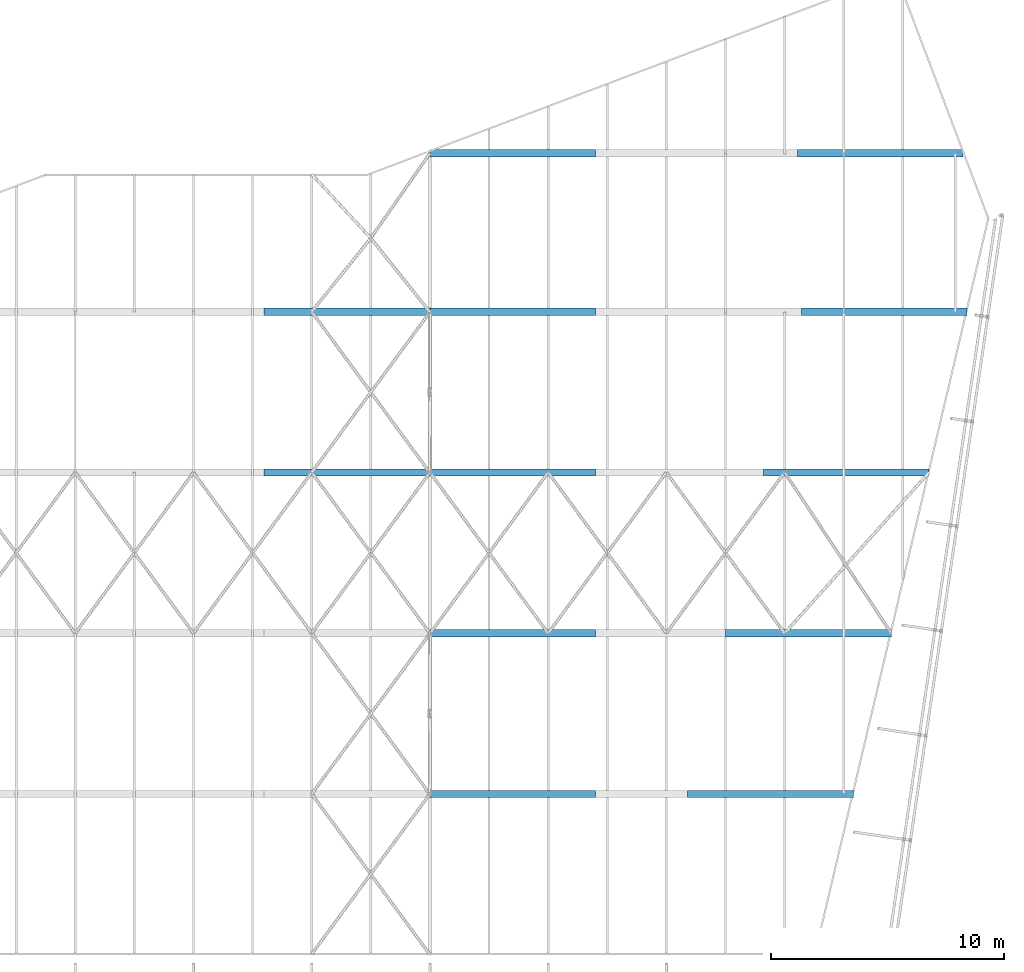
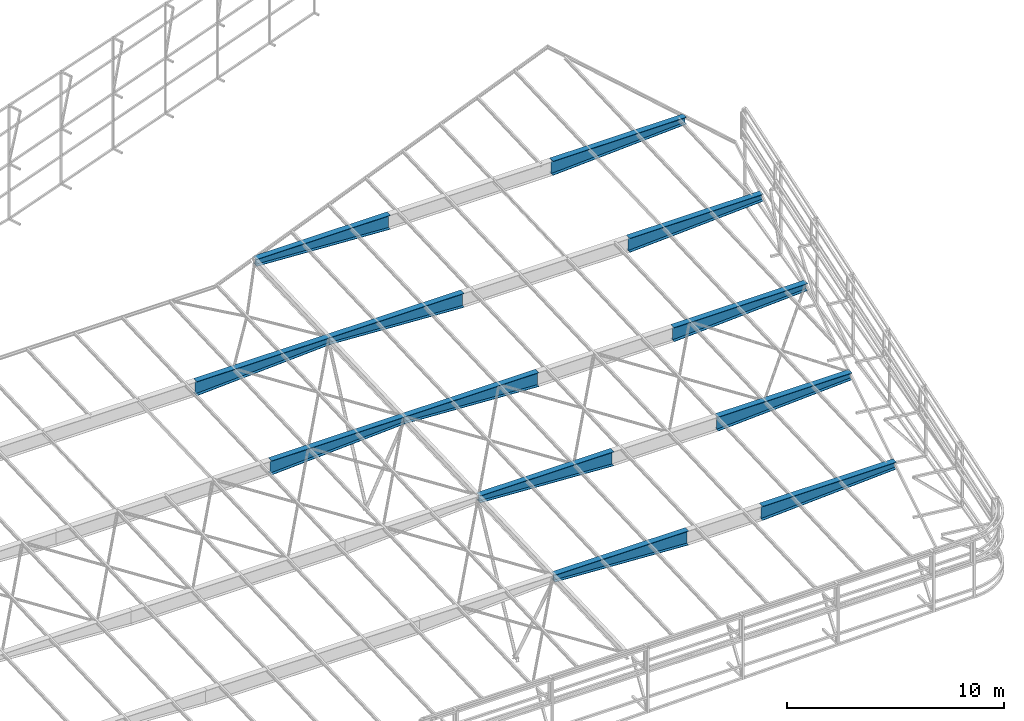
# One storey, part 215 of 215: 12 beams, 12 elements without a shape of their own.
"""IFC2X3 building model written with IfcOpenShell, lengths in millimetres."""

from ifc_helpers import new_model, si_unit, frame, origin_with_axes, place, context, subcontext, project, spatial, faceted_brep, material, type_object, element, aggregate, save


model = new_model("IFC2X3")

# Units and contexts
model_context = context("Model", 3, precision=1e-05, world=origin_with_axes())
body_context = subcontext(model_context, "Body", "Model", "MODEL_VIEW")
ifc_project = project(units=[si_unit("LENGTHUNIT", "METRE", prefix="MILLI"), si_unit("AREAUNIT", "SQUARE_METRE"), si_unit("VOLUMEUNIT", "CUBIC_METRE"), si_unit("MASSUNIT", "GRAM", prefix="KILO"), si_unit("TIMEUNIT", "SECOND"), si_unit("PLANEANGLEUNIT", "RADIAN"), si_unit("SOLIDANGLEUNIT", "STERADIAN"), si_unit("THERMODYNAMICTEMPERATUREUNIT", "DEGREE_CELSIUS"), si_unit("LUMINOUSINTENSITYUNIT", "LUMEN")], contexts=[model_context])

# Site, building, storey
site_placement = place(None, origin_with_axes())
site = spatial("IfcSite", under=ifc_project, at=site_placement, CompositionType="ELEMENT")
building_placement = place(site_placement, origin_with_axes())
building = spatial("IfcBuilding", under=site, at=building_placement, Name="Undefined", CompositionType="ELEMENT")
storey_placement = place(building_placement, origin_with_axes())
storey = spatial("IfcBuildingStorey", under=building, at=storey_placement, Name="Undefined", CompositionType="ELEMENT", Elevation=0.0)

# Assembly, beam
assembly_1_placement = place(storey_placement, origin_with_axes())
assembly_1 = element("IfcElementAssembly", 1, at=assembly_1_placement, inside=storey, Name="Steel Assembly", AssemblyPlace="NOTDEFINED", PredefinedType="RIGID_FRAME")
ifc_material = material(Name="STEEL/S355JR")
beam_type = type_object("IfcBeamType", PredefinedType="NOTDEFINED")
beam_1_placement = place(assembly_1_placement, frame((122402.809360299, 62582.036399848, 3827.69277739953), z_axis=(0.0, 0.0, -1.0), x_axis=(0.999999999241877, 3.89390000093188e-05, -9.99999996354785e-10)))
beam_1 = element("IfcBeam", 2, at=beam_1_placement, type_object=beam_type, material=ifc_material, Name="POUTRE", context=body_context, shape_type="Brep", body=[
    faceted_brep([(-2.91038304567337e-11, 160.000000000007, -200.0), (-2.91038304567337e-11, 160.000000000015, -180.0), (7122.15708385454, 160.000000000007, -180.0), (7122.15708385454, 160.000000000007, -200.0), (-2.91038304567337e-11, 3.00000000000728, -180.0), (7122.15708385453, 3.00000000000728, -180.0), (-1.45519152283669e-11, 3.00000000000728, 579.968482277901), (7122.15708385454, 3.00000000000728, 179.968482277901), (-2.91038304567337e-11, 160.000000000015, 579.968482277902), (7122.15708385454, 160.000000000007, 179.968482277902), (-4.36557456851006e-11, 160.000000000015, 600.0), (7122.15708385454, 160.000000000015, 200.0), (-2.91038304567337e-11, -159.999999999993, 600.0), (7122.15708385454, -160.0, 200.0), (-1.45519152283669e-11, -160.0, 579.968482277902), (7122.15708385454, -160.0, 179.968482277902), (-1.45519152283669e-11, -2.99999999998545, 579.968482277902), (7122.15708385453, -2.99999999998545, 179.968482277902), (-1.45519152283669e-11, -2.99999999998545, -180.0), (7122.15708385453, -2.99999999998545, -180.0), (-2.91038304567337e-11, -160.0, -180.0), (7122.15708385453, -160.0, -180.0), (-1.45519152283669e-11, -160.0, -200.0), (7122.15708385454, -160.0, -200.0)], [[[0, 1, 2, 3]], [[1, 4, 5, 2]], [[4, 6, 7, 5]], [[6, 8, 9, 7]], [[8, 10, 11, 9]], [[10, 12, 13, 11]], [[12, 14, 15, 13]], [[14, 16, 17, 15]], [[16, 18, 19, 17]], [[18, 20, 21, 19]], [[20, 22, 23, 21]], [[22, 0, 3, 23]], [[5, 7, 9, 11, 13, 15, 17, 19, 21, 23, 3, 2]], [[22, 20, 18, 16, 14, 12, 10, 8, 6, 4, 1, 0]]]),
])
aggregate(assembly_1, [beam_1])

assembly_2_placement = place(storey_placement, origin_with_axes())
assembly_2 = element("IfcElementAssembly", 3, at=assembly_2_placement, inside=storey, Name="Steel Assembly", AssemblyPlace="NOTDEFINED", PredefinedType="RIGID_FRAME")
beam_2_placement = place(assembly_2_placement, frame((122402.809360565, 55675.1952876719, 3551.4208334292), z_axis=(0.0, 0.0, -1.0), x_axis=(0.999999999241877, 3.89390000093188e-05, -9.99999996354785e-10)))
beam_2 = element("IfcBeam", 4, at=beam_2_placement, type_object=beam_type, material=ifc_material, Name="POUTRE", context=body_context, shape_type="Brep", body=[
    faceted_brep([(-2.91038304567337e-11, 160.000000000007, -200.0), (-2.91038304567337e-11, 160.000000000015, -180.0), (7122.15708385454, 160.000000000007, -180.0), (7122.15708385454, 160.000000000007, -200.0), (-2.91038304567337e-11, 3.00000000000728, -180.0), (7122.15708385453, 3.00000000000728, -180.0), (-1.45519152283669e-11, 3.00000000000728, 579.968482277901), (7122.15708385454, 3.00000000000728, 179.968482277901), (-2.91038304567337e-11, 160.000000000015, 579.968482277902), (7122.15708385454, 160.000000000007, 179.968482277902), (-4.36557456851006e-11, 160.000000000015, 600.0), (7122.15708385454, 160.000000000015, 200.0), (-2.91038304567337e-11, -159.999999999993, 600.0), (7122.15708385454, -160.0, 200.0), (-1.45519152283669e-11, -160.0, 579.968482277902), (7122.15708385454, -160.0, 179.968482277902), (-1.45519152283669e-11, -2.99999999998545, 579.968482277902), (7122.15708385453, -2.99999999998545, 179.968482277902), (-1.45519152283669e-11, -2.99999999998545, -180.0), (7122.15708385453, -2.99999999998545, -180.0), (-2.91038304567337e-11, -160.0, -180.0), (7122.15708385453, -160.0, -180.0), (-1.45519152283669e-11, -160.0, -200.0), (7122.15708385454, -160.0, -200.0)], [[[0, 1, 2, 3]], [[1, 4, 5, 2]], [[4, 6, 7, 5]], [[6, 8, 9, 7]], [[8, 10, 11, 9]], [[10, 12, 13, 11]], [[12, 14, 15, 13]], [[14, 16, 17, 15]], [[16, 18, 19, 17]], [[18, 20, 21, 19]], [[20, 22, 23, 21]], [[22, 0, 3, 23]], [[5, 7, 9, 11, 13, 15, 17, 19, 21, 23, 3, 2]], [[22, 20, 18, 16, 14, 12, 10, 8, 6, 4, 1, 0]]]),
])
aggregate(assembly_2, [beam_2])

assembly_3_placement = place(storey_placement, origin_with_axes())
assembly_3 = element("IfcElementAssembly", 5, at=assembly_3_placement, inside=storey, Name="Steel Assembly", AssemblyPlace="NOTDEFINED", PredefinedType="RIGID_FRAME")
beam_3_placement = place(assembly_3_placement, frame((136647.174047591, 69388.7234176693, 4099.95302041668), z_axis=(0.0, 0.0, -1.0), x_axis=(-0.999999999241877, 3.8939000009165e-05, -1.00000005517436e-09)))
beam_3 = element("IfcBeam", 6, at=beam_3_placement, type_object=beam_type, material=ifc_material, Name="POUTRE", context=body_context, shape_type="Brep", body=[
    faceted_brep([(-2.91038304567337e-11, 160.000000000007, -200.0), (-2.91038304567337e-11, 160.000000000015, -180.0), (7122.15708385454, 160.000000000007, -180.0), (7122.15708385454, 160.000000000007, -200.0), (-2.91038304567337e-11, 3.00000000000728, -180.0), (7122.15708385453, 3.00000000000728, -180.0), (-1.45519152283669e-11, 3.00000000000728, 579.968482277901), (7122.15708385454, 3.00000000000728, 179.968482277901), (-2.91038304567337e-11, 160.000000000015, 579.968482277902), (7122.15708385454, 160.000000000007, 179.968482277902), (-4.36557456851006e-11, 160.000000000015, 600.0), (7122.15708385454, 160.000000000015, 200.0), (-2.91038304567337e-11, -159.999999999993, 600.0), (7122.15708385454, -160.0, 200.0), (-1.45519152283669e-11, -160.0, 579.968482277902), (7122.15708385454, -160.0, 179.968482277902), (-1.45519152283669e-11, -2.99999999998545, 579.968482277902), (7122.15708385453, -2.99999999998545, 179.968482277902), (-1.45519152283669e-11, -2.99999999998545, -180.0), (7122.15708385453, -2.99999999998545, -180.0), (-2.91038304567337e-11, -160.0, -180.0), (7122.15708385453, -160.0, -180.0), (-1.45519152283669e-11, -160.0, -200.0), (7122.15708385454, -160.0, -200.0)], [[[0, 1, 2, 3]], [[1, 4, 5, 2]], [[4, 6, 7, 5]], [[6, 8, 9, 7]], [[8, 10, 11, 9]], [[10, 12, 13, 11]], [[12, 14, 15, 13]], [[14, 16, 17, 15]], [[16, 18, 19, 17]], [[18, 20, 21, 19]], [[20, 22, 23, 21]], [[22, 0, 3, 23]], [[5, 7, 9, 11, 13, 15, 17, 19, 21, 23, 3, 2]], [[22, 20, 18, 16, 14, 12, 10, 8, 6, 4, 1, 0]]]),
])
aggregate(assembly_3, [beam_3])

assembly_4_placement = place(storey_placement, origin_with_axes())
assembly_4 = element("IfcElementAssembly", 7, at=assembly_4_placement, inside=storey, Name="Steel Assembly", AssemblyPlace="NOTDEFINED", PredefinedType="RIGID_FRAME")
beam_4_placement = place(assembly_4_placement, frame((136647.210639701, 62582.036399848, 3827.69277739953), z_axis=(0.0, 0.0, -1.0), x_axis=(-0.999999999241877, 3.8939000009165e-05, -1.00000005517436e-09)))
beam_4 = element("IfcBeam", 8, at=beam_4_placement, type_object=beam_type, material=ifc_material, Name="POUTRE", context=body_context, shape_type="Brep", body=[
    faceted_brep([(-2.91038304567337e-11, 160.000000000007, -200.0), (-2.91038304567337e-11, 160.000000000015, -180.0), (7122.15708385454, 160.000000000007, -180.0), (7122.15708385454, 160.000000000007, -200.0), (-2.91038304567337e-11, 3.00000000000728, -180.0), (7122.15708385453, 3.00000000000728, -180.0), (-1.45519152283669e-11, 3.00000000000728, 579.968482277901), (7122.15708385454, 3.00000000000728, 179.968482277901), (-2.91038304567337e-11, 160.000000000015, 579.968482277902), (7122.15708385454, 160.000000000007, 179.968482277902), (-4.36557456851006e-11, 160.000000000015, 600.0), (7122.15708385454, 160.000000000015, 200.0), (-2.91038304567337e-11, -159.999999999993, 600.0), (7122.15708385454, -160.0, 200.0), (-1.45519152283669e-11, -160.0, 579.968482277902), (7122.15708385454, -160.0, 179.968482277902), (-1.45519152283669e-11, -2.99999999998545, 579.968482277902), (7122.15708385453, -2.99999999998545, 179.968482277902), (-1.45519152283669e-11, -2.99999999998545, -180.0), (7122.15708385453, -2.99999999998545, -180.0), (-2.91038304567337e-11, -160.0, -180.0), (7122.15708385453, -160.0, -180.0), (-1.45519152283669e-11, -160.0, -200.0), (7122.15708385454, -160.0, -200.0)], [[[0, 1, 2, 3]], [[1, 4, 5, 2]], [[4, 6, 7, 5]], [[6, 8, 9, 7]], [[8, 10, 11, 9]], [[10, 12, 13, 11]], [[12, 14, 15, 13]], [[14, 16, 17, 15]], [[16, 18, 19, 17]], [[18, 20, 21, 19]], [[20, 22, 23, 21]], [[22, 0, 3, 23]], [[5, 7, 9, 11, 13, 15, 17, 19, 21, 23, 3, 2]], [[22, 20, 18, 16, 14, 12, 10, 8, 6, 4, 1, 0]]]),
])
aggregate(assembly_4, [beam_4])

assembly_5_placement = place(storey_placement, origin_with_axes())
assembly_5 = element("IfcElementAssembly", 9, at=assembly_5_placement, inside=storey, Name="Steel Assembly", AssemblyPlace="NOTDEFINED", PredefinedType="RIGID_FRAME")
beam_5_placement = place(assembly_5_placement, frame((136647.210639435, 55675.1952876719, 3551.4208334292), z_axis=(0.0, 0.0, -1.0), x_axis=(-0.999999999241877, 3.8939000009165e-05, -1.00000005517436e-09)))
beam_5 = element("IfcBeam", 10, at=beam_5_placement, type_object=beam_type, material=ifc_material, Name="POUTRE", context=body_context, shape_type="Brep", body=[
    faceted_brep([(-2.91038304567337e-11, 160.000000000007, -200.0), (-2.91038304567337e-11, 160.000000000015, -180.0), (7122.15708385454, 160.000000000007, -180.0), (7122.15708385454, 160.000000000007, -200.0), (-2.91038304567337e-11, 3.00000000000728, -180.0), (7122.15708385453, 3.00000000000728, -180.0), (-1.45519152283669e-11, 3.00000000000728, 579.968482277901), (7122.15708385454, 3.00000000000728, 179.968482277901), (-2.91038304567337e-11, 160.000000000015, 579.968482277902), (7122.15708385454, 160.000000000007, 179.968482277902), (-4.36557456851006e-11, 160.000000000015, 600.0), (7122.15708385454, 160.000000000015, 200.0), (-2.91038304567337e-11, -159.999999999993, 600.0), (7122.15708385454, -160.0, 200.0), (-1.45519152283669e-11, -160.0, 579.968482277902), (7122.15708385454, -160.0, 179.968482277902), (-1.45519152283669e-11, -2.99999999998545, 579.968482277902), (7122.15708385453, -2.99999999998545, 179.968482277902), (-1.45519152283669e-11, -2.99999999998545, -180.0), (7122.15708385453, -2.99999999998545, -180.0), (-2.91038304567337e-11, -160.0, -180.0), (7122.15708385453, -160.0, -180.0), (-1.45519152283669e-11, -160.0, -200.0), (7122.15708385454, -160.0, -200.0)], [[[0, 1, 2, 3]], [[1, 4, 5, 2]], [[4, 6, 7, 5]], [[6, 8, 9, 7]], [[8, 10, 11, 9]], [[10, 12, 13, 11]], [[12, 14, 15, 13]], [[14, 16, 17, 15]], [[16, 18, 19, 17]], [[18, 20, 21, 19]], [[20, 22, 23, 21]], [[22, 0, 3, 23]], [[5, 7, 9, 11, 13, 15, 17, 19, 21, 23, 3, 2]], [[22, 20, 18, 16, 14, 12, 10, 8, 6, 4, 1, 0]]]),
])
aggregate(assembly_5, [beam_5])

assembly_6_placement = place(storey_placement, origin_with_axes())
assembly_6 = element("IfcElementAssembly", 11, at=assembly_6_placement, inside=storey, Name="Steel Assembly", AssemblyPlace="NOTDEFINED", PredefinedType="RIGID_FRAME")
beam_6_placement = place(assembly_6_placement, frame((136647.174046746, 48768.3616230716, 3275.14889202867), z_axis=(0.0, 0.0, -1.0), x_axis=(-0.999999999241877, 3.8939000009165e-05, -1.00000005517436e-09)))
beam_6 = element("IfcBeam", 12, at=beam_6_placement, type_object=beam_type, material=ifc_material, Name="POUTRE", context=body_context, shape_type="Brep", body=[
    faceted_brep([(-2.91038304567337e-11, 160.000000000007, -200.0), (-2.91038304567337e-11, 160.000000000015, -180.0), (7122.15708385454, 160.000000000007, -180.0), (7122.15708385454, 160.000000000007, -200.0), (-2.91038304567337e-11, 3.00000000000728, -180.0), (7122.15708385453, 3.00000000000728, -180.0), (-1.45519152283669e-11, 3.00000000000728, 579.968482277901), (7122.15708385454, 3.00000000000728, 179.968482277901), (-2.91038304567337e-11, 160.000000000015, 579.968482277902), (7122.15708385454, 160.000000000007, 179.968482277902), (-4.36557456851006e-11, 160.000000000015, 600.0), (7122.15708385454, 160.000000000015, 200.0), (-2.91038304567337e-11, -159.999999999993, 600.0), (7122.15708385454, -160.0, 200.0), (-1.45519152283669e-11, -160.0, 579.968482277902), (7122.15708385454, -160.0, 179.968482277902), (-1.45519152283669e-11, -2.99999999998545, 579.968482277902), (7122.15708385453, -2.99999999998545, 179.968482277902), (-1.45519152283669e-11, -2.99999999998545, -180.0), (7122.15708385453, -2.99999999998545, -180.0), (-2.91038304567337e-11, -160.0, -180.0), (7122.15708385453, -160.0, -180.0), (-1.45519152283669e-11, -160.0, -200.0), (7122.15708385454, -160.0, -200.0)], [[[0, 1, 2, 3]], [[1, 4, 5, 2]], [[4, 6, 7, 5]], [[6, 8, 9, 7]], [[8, 10, 11, 9]], [[10, 12, 13, 11]], [[12, 14, 15, 13]], [[14, 16, 17, 15]], [[16, 18, 19, 17]], [[18, 20, 21, 19]], [[20, 22, 23, 21]], [[22, 0, 3, 23]], [[5, 7, 9, 11, 13, 15, 17, 19, 21, 23, 3, 2]], [[22, 20, 18, 16, 14, 12, 10, 8, 6, 4, 1, 0]]]),
])
aggregate(assembly_6, [beam_6])

assembly_7_placement = place(storey_placement, origin_with_axes())
assembly_7 = element("IfcElementAssembly", 13, at=assembly_7_placement, inside=storey, Name="Steel Assembly", AssemblyPlace="NOTDEFINED", PredefinedType="RIGID_FRAME")
beam_7_placement = place(assembly_7_placement, frame((136647.174046471, 41861.524234683, 2998.87694988713), z_axis=(0.0, 0.0, -1.0), x_axis=(-0.999999999241877, 3.8939000009165e-05, -1.00000005517436e-09)))
beam_7 = element("IfcBeam", 14, at=beam_7_placement, type_object=beam_type, material=ifc_material, Name="POUTRE", context=body_context, shape_type="Brep", body=[
    faceted_brep([(-2.91038304567337e-11, 160.000000000007, -200.0), (-2.91038304567337e-11, 160.000000000015, -180.0), (7122.15708385454, 160.000000000007, -180.0), (7122.15708385454, 160.000000000007, -200.0), (-2.91038304567337e-11, 3.00000000000728, -180.0), (7122.15708385453, 3.00000000000728, -180.0), (-1.45519152283669e-11, 3.00000000000728, 579.968482277901), (7122.15708385454, 3.00000000000728, 179.968482277901), (-2.91038304567337e-11, 160.000000000015, 579.968482277902), (7122.15708385454, 160.000000000007, 179.968482277902), (-4.36557456851006e-11, 160.000000000015, 600.0), (7122.15708385454, 160.000000000015, 200.0), (-2.91038304567337e-11, -159.999999999993, 600.0), (7122.15708385454, -160.0, 200.0), (-1.45519152283669e-11, -160.0, 579.968482277902), (7122.15708385454, -160.0, 179.968482277902), (-1.45519152283669e-11, -2.99999999998545, 579.968482277902), (7122.15708385453, -2.99999999998545, 179.968482277902), (-1.45519152283669e-11, -2.99999999998545, -180.0), (7122.15708385453, -2.99999999998545, -180.0), (-2.91038304567337e-11, -160.0, -180.0), (7122.15708385453, -160.0, -180.0), (-1.45519152283669e-11, -160.0, -200.0), (7122.15708385454, -160.0, -200.0)], [[[0, 1, 2, 3]], [[1, 4, 5, 2]], [[4, 6, 7, 5]], [[6, 8, 9, 7]], [[8, 10, 11, 9]], [[10, 12, 13, 11]], [[12, 14, 15, 13]], [[14, 16, 17, 15]], [[16, 18, 19, 17]], [[18, 20, 21, 19]], [[20, 22, 23, 21]], [[22, 0, 3, 23]], [[5, 7, 9, 11, 13, 15, 17, 19, 21, 23, 3, 2]], [[22, 20, 18, 16, 14, 12, 10, 8, 6, 4, 1, 0]]]),
])
aggregate(assembly_7, [beam_7])

assembly_8_placement = place(storey_placement, origin_with_axes())
assembly_8 = element("IfcElementAssembly", 15, at=assembly_8_placement, inside=storey, Name="Steel Assembly", AssemblyPlace="NOTDEFINED", PredefinedType="RIGID_FRAME")
beam_8_placement = place(assembly_8_placement, frame((145308.729662132, 69388.5548629645, 4099.94889148791), z_axis=(0.0, 0.0, -1.0), x_axis=(0.999999999241877, 3.89390000093188e-05, -9.99999996354785e-10)))
beam_8 = element("IfcBeam", 16, at=beam_8_placement, type_object=beam_type, material=ifc_material, Name="POUTRE", context=body_context, shape_type="Brep", body=[
    faceted_brep([(-2.91038304567337e-11, 160.000000000007, -200.0), (-2.91038304567337e-11, 160.000000000015, -180.0), (7122.15708385454, 160.000000000007, -180.0), (7122.15708385454, 160.000000000007, -200.0), (-2.91038304567337e-11, 3.00000000000728, -180.0), (7122.15708385453, 3.00000000000728, -180.0), (-1.45519152283669e-11, 3.00000000000728, 579.968482277901), (7122.15708385454, 3.00000000000728, 179.968482277901), (-2.91038304567337e-11, 160.000000000015, 579.968482277902), (7122.15708385454, 160.000000000007, 179.968482277902), (-4.36557456851006e-11, 160.000000000015, 600.0), (7122.15708385454, 160.000000000015, 200.0), (-2.91038304567337e-11, -159.999999999993, 600.0), (7122.15708385454, -160.0, 200.0), (-1.45519152283669e-11, -160.0, 579.968482277902), (7122.15708385454, -160.0, 179.968482277902), (-1.45519152283669e-11, -2.99999999998545, 579.968482277902), (7122.15708385453, -2.99999999998545, 179.968482277902), (-1.45519152283669e-11, -2.99999999998545, -180.0), (7122.15708385453, -2.99999999998545, -180.0), (-2.91038304567337e-11, -160.0, -180.0), (7122.15708385453, -160.0, -180.0), (-1.45519152283669e-11, -160.0, -200.0), (7122.15708385454, -160.0, -200.0)], [[[0, 1, 2, 3]], [[1, 4, 5, 2]], [[4, 6, 7, 5]], [[6, 8, 9, 7]], [[8, 10, 11, 9]], [[10, 12, 13, 11]], [[12, 14, 15, 13]], [[14, 16, 17, 15]], [[16, 18, 19, 17]], [[18, 20, 21, 19]], [[20, 22, 23, 21]], [[22, 0, 3, 23]], [[5, 7, 9, 11, 13, 15, 17, 19, 21, 23, 3, 2]], [[22, 20, 18, 16, 14, 12, 10, 8, 6, 4, 1, 0]]]),
])
aggregate(assembly_8, [beam_8])

assembly_9_placement = place(storey_placement, origin_with_axes())
assembly_9 = element("IfcElementAssembly", 17, at=assembly_9_placement, inside=storey, Name="Steel Assembly", AssemblyPlace="NOTDEFINED", PredefinedType="RIGID_FRAME")
beam_9_placement = place(assembly_9_placement, frame((145479.857476562, 62582.0309406506, 3827.68889148791), z_axis=(0.0, 0.0, -1.0), x_axis=(0.999999999241877, 3.89390000093188e-05, -9.99999996354785e-10)))
beam_9 = element("IfcBeam", 18, at=beam_9_placement, type_object=beam_type, material=ifc_material, Name="POUTRE", context=body_context, shape_type="Brep", body=[
    faceted_brep([(-2.91038304567337e-11, 160.000000000007, -200.0), (-2.91038304567337e-11, 160.000000000015, -180.0), (7122.15708385454, 160.000000000007, -180.0), (7122.15708385454, 160.000000000007, -200.0), (-2.91038304567337e-11, 3.00000000000728, -180.0), (7122.15708385453, 3.00000000000728, -180.0), (-1.45519152283669e-11, 3.00000000000728, 579.968482277901), (7122.15708385454, 3.00000000000728, 179.968482277901), (-2.91038304567337e-11, 160.000000000015, 579.968482277902), (7122.15708385454, 160.000000000007, 179.968482277902), (-4.36557456851006e-11, 160.000000000015, 600.0), (7122.15708385454, 160.000000000015, 200.0), (-2.91038304567337e-11, -159.999999999993, 600.0), (7122.15708385454, -160.0, 200.0), (-1.45519152283669e-11, -160.0, 579.968482277902), (7122.15708385454, -160.0, 179.968482277902), (-1.45519152283669e-11, -2.99999999998545, 579.968482277902), (7122.15708385453, -2.99999999998545, 179.968482277902), (-1.45519152283669e-11, -2.99999999998545, -180.0), (7122.15708385453, -2.99999999998545, -180.0), (-2.91038304567337e-11, -160.0, -180.0), (7122.15708385453, -160.0, -180.0), (-1.45519152283669e-11, -160.0, -200.0), (7122.15708385454, -160.0, -200.0)], [[[0, 1, 2, 3]], [[1, 4, 5, 2]], [[4, 6, 7, 5]], [[6, 8, 9, 7]], [[8, 10, 11, 9]], [[10, 12, 13, 11]], [[12, 14, 15, 13]], [[14, 16, 17, 15]], [[16, 18, 19, 17]], [[18, 20, 21, 19]], [[20, 22, 23, 21]], [[22, 0, 3, 23]], [[5, 7, 9, 11, 13, 15, 17, 19, 21, 23, 3, 2]], [[22, 20, 18, 16, 14, 12, 10, 8, 6, 4, 1, 0]]]),
])
aggregate(assembly_9, [beam_9])

assembly_10_placement = place(storey_placement, origin_with_axes())
assembly_10 = element("IfcElementAssembly", 19, at=assembly_10_placement, inside=storey, Name="Steel Assembly", AssemblyPlace="NOTDEFINED", PredefinedType="RIGID_FRAME")
beam_10_placement = place(assembly_10_placement, frame((143852.463808377, 55675.4484588129, 3551.4208338406), z_axis=(0.0, 0.0, -1.0), x_axis=(0.999999999241877, 3.89390000093188e-05, -9.99999996354785e-10)))
beam_10 = element("IfcBeam", 20, at=beam_10_placement, type_object=beam_type, material=ifc_material, Name="POUTRE", context=body_context, shape_type="Brep", body=[
    faceted_brep([(-2.91038304567337e-11, 160.000000000007, -200.0), (-2.91038304567337e-11, 160.000000000015, -180.0), (7122.15708385454, 160.000000000007, -180.0), (7122.15708385454, 160.000000000007, -200.0), (-2.91038304567337e-11, 3.00000000000728, -180.0), (7122.15708385453, 3.00000000000728, -180.0), (-1.45519152283669e-11, 3.00000000000728, 579.968482277901), (7122.15708385454, 3.00000000000728, 179.968482277901), (-2.91038304567337e-11, 160.000000000015, 579.968482277902), (7122.15708385454, 160.000000000007, 179.968482277902), (-4.36557456851006e-11, 160.000000000015, 600.0), (7122.15708385454, 160.000000000015, 200.0), (-2.91038304567337e-11, -159.999999999993, 600.0), (7122.15708385454, -160.0, 200.0), (-1.45519152283669e-11, -160.0, 579.968482277902), (7122.15708385454, -160.0, 179.968482277902), (-1.45519152283669e-11, -2.99999999998545, 579.968482277902), (7122.15708385453, -2.99999999998545, 179.968482277902), (-1.45519152283669e-11, -2.99999999998545, -180.0), (7122.15708385453, -2.99999999998545, -180.0), (-2.91038304567337e-11, -160.0, -180.0), (7122.15708385453, -160.0, -180.0), (-1.45519152283669e-11, -160.0, -200.0), (7122.15708385454, -160.0, -200.0)], [[[0, 1, 2, 3]], [[1, 4, 5, 2]], [[4, 6, 7, 5]], [[6, 8, 9, 7]], [[8, 10, 11, 9]], [[10, 12, 13, 11]], [[12, 14, 15, 13]], [[14, 16, 17, 15]], [[16, 18, 19, 17]], [[18, 20, 21, 19]], [[20, 22, 23, 21]], [[22, 0, 3, 23]], [[5, 7, 9, 11, 13, 15, 17, 19, 21, 23, 3, 2]], [[22, 20, 18, 16, 14, 12, 10, 8, 6, 4, 1, 0]]]),
])
aggregate(assembly_10, [beam_10])

assembly_11_placement = place(storey_placement, origin_with_axes())
assembly_11 = element("IfcElementAssembly", 21, at=assembly_11_placement, inside=storey, Name="Steel Assembly", AssemblyPlace="NOTDEFINED", PredefinedType="RIGID_FRAME")
beam_11_placement = place(assembly_11_placement, frame((140597.50037205, 41861.524234683, 2998.87694988713), z_axis=(0.0, 0.0, -1.0), x_axis=(0.999999999241877, 3.89390000093188e-05, -9.99999996354785e-10)))
beam_11 = element("IfcBeam", 22, at=beam_11_placement, type_object=beam_type, material=ifc_material, Name="POUTRE", context=body_context, shape_type="Brep", body=[
    faceted_brep([(-2.91038304567337e-11, 160.000000000007, -200.0), (-2.91038304567337e-11, 160.000000000015, -180.0), (7122.15708385454, 160.000000000007, -180.0), (7122.15708385454, 160.000000000007, -200.0), (-2.91038304567337e-11, 3.00000000000728, -180.0), (7122.15708385453, 3.00000000000728, -180.0), (-1.45519152283669e-11, 3.00000000000728, 579.968482277901), (7122.15708385454, 3.00000000000728, 179.968482277901), (-2.91038304567337e-11, 160.000000000015, 579.968482277902), (7122.15708385454, 160.000000000007, 179.968482277902), (-4.36557456851006e-11, 160.000000000015, 600.0), (7122.15708385454, 160.000000000015, 200.0), (-2.91038304567337e-11, -159.999999999993, 600.0), (7122.15708385454, -160.0, 200.0), (-1.45519152283669e-11, -160.0, 579.968482277902), (7122.15708385454, -160.0, 179.968482277902), (-1.45519152283669e-11, -2.99999999998545, 579.968482277902), (7122.15708385453, -2.99999999998545, 179.968482277902), (-1.45519152283669e-11, -2.99999999998545, -180.0), (7122.15708385453, -2.99999999998545, -180.0), (-2.91038304567337e-11, -160.0, -180.0), (7122.15708385453, -160.0, -180.0), (-1.45519152283669e-11, -160.0, -200.0), (7122.15708385454, -160.0, -200.0)], [[[0, 1, 2, 3]], [[1, 4, 5, 2]], [[4, 6, 7, 5]], [[6, 8, 9, 7]], [[8, 10, 11, 9]], [[10, 12, 13, 11]], [[12, 14, 15, 13]], [[14, 16, 17, 15]], [[16, 18, 19, 17]], [[18, 20, 21, 19]], [[20, 22, 23, 21]], [[22, 0, 3, 23]], [[5, 7, 9, 11, 13, 15, 17, 19, 21, 23, 3, 2]], [[22, 20, 18, 16, 14, 12, 10, 8, 6, 4, 1, 0]]]),
])
aggregate(assembly_11, [beam_11])

assembly_12_placement = place(storey_placement, origin_with_axes())
assembly_12 = element("IfcElementAssembly", 23, at=assembly_12_placement, inside=storey, Name="Steel Assembly", AssemblyPlace="NOTDEFINED", PredefinedType="RIGID_FRAME")
beam_12_placement = place(assembly_12_placement, frame((142225.010564092, 48768.6131387569, 3275.14889148791), z_axis=(0.0, 0.0, -1.0), x_axis=(0.999999999241877, 3.89390000093188e-05, -9.99999996354785e-10)))
beam_12 = element("IfcBeam", 24, at=beam_12_placement, type_object=beam_type, material=ifc_material, Name="POUTRE", context=body_context, shape_type="Brep", body=[
    faceted_brep([(-2.91038304567337e-11, 160.000000000007, -200.0), (-2.91038304567337e-11, 160.000000000015, -180.0), (7122.15708385454, 160.000000000007, -180.0), (7122.15708385454, 160.000000000007, -200.0), (-2.91038304567337e-11, 3.00000000000728, -180.0), (7122.15708385453, 3.00000000000728, -180.0), (-1.45519152283669e-11, 3.00000000000728, 579.968482277901), (7122.15708385454, 3.00000000000728, 179.968482277901), (-2.91038304567337e-11, 160.000000000015, 579.968482277902), (7122.15708385454, 160.000000000007, 179.968482277902), (-4.36557456851006e-11, 160.000000000015, 600.0), (7122.15708385454, 160.000000000015, 200.0), (-2.91038304567337e-11, -159.999999999993, 600.0), (7122.15708385454, -160.0, 200.0), (-1.45519152283669e-11, -160.0, 579.968482277902), (7122.15708385454, -160.0, 179.968482277902), (-1.45519152283669e-11, -2.99999999998545, 579.968482277902), (7122.15708385453, -2.99999999998545, 179.968482277902), (-1.45519152283669e-11, -2.99999999998545, -180.0), (7122.15708385453, -2.99999999998545, -180.0), (-2.91038304567337e-11, -160.0, -180.0), (7122.15708385453, -160.0, -180.0), (-1.45519152283669e-11, -160.0, -200.0), (7122.15708385454, -160.0, -200.0)], [[[0, 1, 2, 3]], [[1, 4, 5, 2]], [[4, 6, 7, 5]], [[6, 8, 9, 7]], [[8, 10, 11, 9]], [[10, 12, 13, 11]], [[12, 14, 15, 13]], [[14, 16, 17, 15]], [[16, 18, 19, 17]], [[18, 20, 21, 19]], [[20, 22, 23, 21]], [[22, 0, 3, 23]], [[5, 7, 9, 11, 13, 15, 17, 19, 21, 23, 3, 2]], [[22, 20, 18, 16, 14, 12, 10, 8, 6, 4, 1, 0]]]),
])
aggregate(assembly_12, [beam_12])

save(model, "model.ifc")
